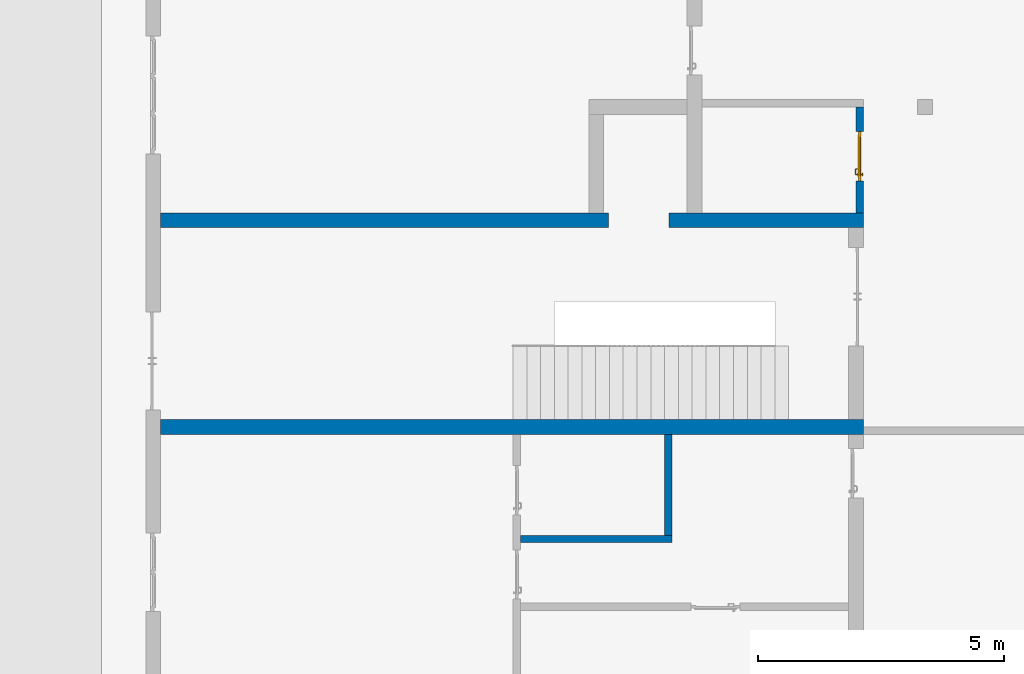
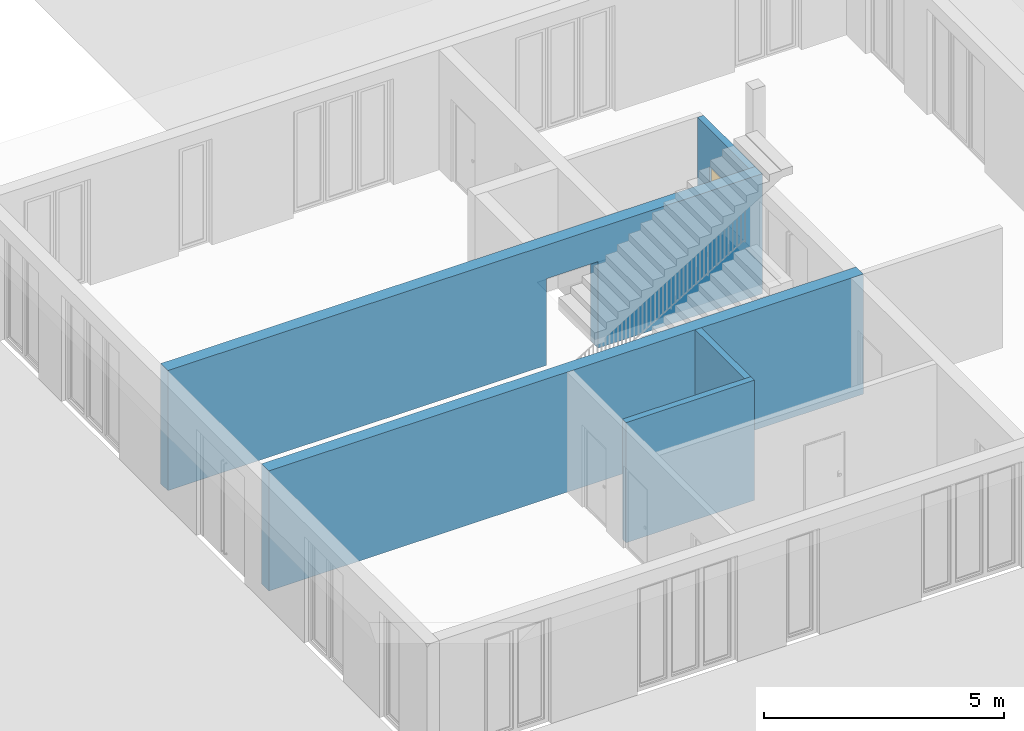
# One storey, part 2 of 23: 5 walls, 1 door, 2 openings.
"""IFC4 building model written with IfcOpenShell, lengths in metres."""

from ifc_helpers import new_model, entity, si_unit, converted_unit, derived_unit, direction, frame, origin_with_axes, place, context, subcontext, project, spatial, polygons, source, transform, mapped, material, type_object, element, fill, save


model = new_model("IFC4")

# Units and contexts
model_context = context("Model", 3, precision=1e-05, world=origin_with_axes(), true_north=direction((0.0, 1.0)))
body_context = subcontext(model_context, "Body", "Model", "MODEL_VIEW")
ifc_project = project(units=[si_unit("LENGTHUNIT", "METRE"), si_unit("AREAUNIT", "SQUARE_METRE"), si_unit("VOLUMEUNIT", "CUBIC_METRE"), converted_unit("PLANEANGLEUNIT", "DEGREE", entity("IfcPlaneAngleMeasure", 0.0174532925199), si_unit("PLANEANGLEUNIT", "RADIAN"), dimensions=[0, 0, 0, 0, 0, 0, 0]), converted_unit("TIMEUNIT", "Year", entity("IfcTimeMeasure", 31556926.0), si_unit("TIMEUNIT", "SECOND"), dimensions=[0, 0, 1, 0, 0, 0, 0]), si_unit("MASSUNIT", "GRAM", prefix="KILO"), si_unit("THERMODYNAMICTEMPERATUREUNIT", "DEGREE_CELSIUS"), si_unit("LUMINOUSINTENSITYUNIT", "LUMEN"), si_unit("ENERGYUNIT", "JOULE", prefix="MEGA"), derived_unit("THERMALCONDUCTANCEUNIT", [(si_unit("POWERUNIT", "WATT"), 1), (si_unit("LENGTHUNIT", "METRE"), -1), (si_unit("THERMODYNAMICTEMPERATUREUNIT", "KELVIN"), -1)]), derived_unit("SPECIFICHEATCAPACITYUNIT", [(si_unit("ENERGYUNIT", "JOULE"), 1), (si_unit("MASSUNIT", "GRAM", prefix="KILO"), -1), (si_unit("THERMODYNAMICTEMPERATUREUNIT", "KELVIN"), -1)]), derived_unit("MASSDENSITYUNIT", [(si_unit("MASSUNIT", "GRAM", prefix="KILO"), 1), (si_unit("VOLUMEUNIT", "CUBIC_METRE"), -1)])], contexts=[model_context])

# Site, building, storey
site_placement = place(None, origin_with_axes())
site = spatial("IfcSite", under=ifc_project, at=site_placement, CompositionType="ELEMENT")
building_placement = place(site_placement, origin_with_axes())
building = spatial("IfcBuilding", under=site, at=building_placement, CompositionType="ELEMENT")
storey_placement = place(building_placement, origin_with_axes())
storey = spatial("IfcBuildingStorey", under=building, at=storey_placement, Name="0. Geschoss", CompositionType="ELEMENT", Elevation=0.0)

# Wall
ifc_material = material()
wall_type_1 = type_object("IfcWallType", Name="300", PredefinedType="NOTDEFINED")
wall_1_placement = place(storey_placement, frame((2.8378006196, -2.52881223104, 0.0), z_axis=(0.0, 0.0, 1.0), x_axis=(-1.0, 0.0, 0.0)))
element("IfcWall", 1, at=wall_1_placement, inside=storey, type_object=wall_type_1, material=ifc_material, Name="Wand-001", PredefinedType="NOTDEFINED", context=body_context, shape_type="Tessellation", body=[
    polygons([(14.28, 0.0, 3.05), (6.28, 0.0, 3.05), (1.8, 0.0, 3.05), (0.0, 0.0, 3.05), (0.0, 0.0, 0.0), (14.28, 0.0, 0.0), (14.28, 0.3, 3.05), (0.0, 0.3, 3.05), (0.0, 0.3, 0.0), (14.28, 0.3, 0.0)], [[[1, 2, 3, 4, 5, 6]], [[4, 3, 2, 1, 7, 8]], [[5, 4, 8, 9]], [[9, 10, 6, 5]], [[10, 7, 1, 6]], [[8, 7, 10, 9]]], closed=True),
])

# Wall, opening
wall_2_placement = place(storey_placement, frame((-11.7421993804, 1.37118776896, 0.0), z_axis=(0.0, 0.0, 1.0), x_axis=(1.0, 0.0, 0.0)))
wall_2 = element("IfcWall", 2, at=wall_2_placement, inside=storey, type_object=wall_type_1, material=ifc_material, Name="Wand-001", PredefinedType="NOTDEFINED", context=body_context, shape_type="Tessellation", body=[
    polygons([(9.4, 0.3, 2.2), (9.4, 0.3, 0.0), (0.3, 0.3, 0.0), (0.3, 0.3, 3.05), (14.58, 0.3, 3.05), (14.58, 0.3, 0.0), (10.63, 0.3, 0.0), (10.63, 0.3, 2.2), (9.4, 0.0, 2.2), (9.4, 0.0, 0.0), (0.3, 0.0, 0.0), (0.3, 0.0, 3.05), (14.58, 0.0, 3.05), (14.58, 0.0, 0.0), (10.63, 0.0, 0.0), (10.63, 0.0, 2.2)], [[[1, 2, 3, 4, 5, 6, 7, 8]], [[2, 1, 9, 10]], [[2, 10, 11, 3]], [[12, 4, 3, 11]], [[13, 5, 4, 12]], [[5, 13, 14, 6]], [[15, 7, 6, 14]], [[8, 7, 15, 16]], [[1, 8, 16, 9]], [[16, 15, 14, 13, 12, 11, 10, 9]]], closed=True),
])
opening_1_placement = place(wall_2_placement, frame((10.015, 0.0, 0.0), z_axis=(0.0, 0.0, 1.0), x_axis=(1.0, 0.0, 0.0)))
element("IfcOpeningElement", 3, at=opening_1_placement, cuts=wall_2, context=body_context, identifier="Reference", shape_type="Tessellation", body=[
    polygons([(-0.615, -0.001, 2.2), (-0.615, -0.001, 0.0), (0.615, -0.001, 0.0), (0.615, -0.001, 2.2), (-0.615, 0.301, 2.2), (-0.615, 0.301, 0.0), (0.615, 0.301, 0.0), (0.615, 0.301, 2.2)], [[[1, 2, 3, 4]], [[5, 6, 2, 1]], [[6, 7, 3, 2]], [[7, 8, 4, 3]], [[8, 5, 1, 4]], [[7, 6, 5, 8]]], closed=True),
])

# Wall
wall_type_2 = type_object("IfcWallType", Name="150", PredefinedType="NOTDEFINED")
wall_3_placement = place(storey_placement, frame((-1.2021993804, -2.52881223104, 0.0), z_axis=(0.0, 0.0, 1.0), x_axis=(0.0, -1.0, 0.0)))
element("IfcWall", 4, at=wall_3_placement, inside=storey, type_object=wall_type_2, material=ifc_material, Name="Wand-002", PredefinedType="NOTDEFINED", context=body_context, shape_type="Tessellation", body=[
    polygons([(0.3, 0.0, 0.0), (0.3, 0.0, 3.05), (0.3, 0.15, 3.05), (0.3, 0.15, 0.0), (2.35, 0.0, 0.0), (2.35, 0.0, 3.05), (2.35, 0.15, 3.05), (2.35, 0.15, 0.0)], [[[1, 2, 3, 4]], [[5, 6, 2, 1]], [[6, 7, 3, 2]], [[4, 3, 7, 8]], [[4, 8, 5, 1]], [[8, 7, 6, 5]]], closed=True),
])

# Wall, opening, door
wall_4_placement = place(storey_placement, frame((2.8378006196, 1.67118776896, 0.0), z_axis=(0.0, 0.0, 1.0), x_axis=(0.0, 1.0, 0.0)))
wall_4 = element("IfcWall", 5, at=wall_4_placement, inside=storey, type_object=wall_type_2, material=ifc_material, Name="Wand-003", PredefinedType="NOTDEFINED", context=body_context, shape_type="Tessellation", body=[
    polygons([(0.65, 0.0, 2.1), (0.65, 0.15, 2.1), (1.65, 0.15, 2.1), (1.65, 0.0, 2.1), (0.65, 0.05, 0.0), (0.65, 0.15, 0.0), (0.65, 0.0, 0.0), (0.0, 0.15, 0.0), (0.0, 0.15, 3.05), (2.15, 0.15, 3.05), (2.15, 0.15, 0.0), (1.65, 0.15, 0.0), (1.65, 0.05, 0.0), (1.65, 0.0, 0.0), (2.15, 0.0, 3.05), (0.0, 0.0, 3.05), (0.0, 0.0, 0.0), (2.15, 0.0, 0.0)], [[[1, 2, 3, 4]], [[5, 6, 2, 1, 7]], [[2, 6, 8, 9, 10, 11, 12, 3]], [[4, 3, 12, 13, 14]], [[15, 16, 17, 7, 1, 4, 14, 18]], [[6, 5, 7, 17, 8]], [[9, 8, 17, 16]], [[15, 10, 9, 16]], [[15, 18, 11, 10]], [[13, 12, 11, 18, 14]]], closed=True),
])
opening_2_placement = place(wall_4_placement, frame((1.15, 0.0, 0.0), z_axis=(0.0, 0.0, 1.0), x_axis=(1.0, 0.0, 0.0)))
opening_2 = element("IfcOpeningElement", 6, at=opening_2_placement, cuts=wall_4, context=body_context, identifier="Reference", shape_type="Tessellation", body=[
    polygons([(0.5, 0.05, 0.0), (0.5, 0.05, 2.1), (0.5, -0.001, 2.1), (0.5, -0.001, 0.0), (0.5, 0.151, 0.0), (0.5, 0.151, 2.1), (-0.5, 0.05, 2.1), (-0.5, -0.001, 2.1), (-0.5, 0.151, 2.1), (-0.5, -0.001, 0.0), (-0.5, 0.05, 0.0), (-0.5, 0.151, 0.0)], [[[1, 2, 3, 4]], [[2, 1, 5, 6]], [[7, 8, 3, 2, 6, 9]], [[8, 10, 4, 3]], [[1, 4, 10, 11, 12, 5]], [[6, 5, 12, 9]], [[7, 11, 10, 8]], [[11, 7, 9, 12]]], closed=True),
])
door_type = type_object("IfcDoorType", Name="Eingang 01 1-Fl 26", OperationType="SINGLE_SWING_RIGHT", PredefinedType="DOOR")
shared_shape = source(origin_with_axes(), body_context, "Body", "Tessellation", [
    polygons([(0.5, -0.05, 0.0), (0.5, -0.03, 0.0), (0.5, -0.03, 2.1), (0.5, -0.05, 2.1), (0.4, -0.05, 0.0), (0.4, -0.03, 0.0), (0.4, -0.03, 2.0), (0.1301, -0.03, 2.0), (0.0001, -0.03, 2.0), (-0.4, -0.03, 2.0), (-0.4, -0.03, 0.0), (-0.5, -0.03, 0.0), (-0.5, -0.03, 2.1), (-0.5, -0.05, 2.1), (-0.5, -0.05, 0.0), (-0.4, -0.05, 0.0), (-0.4, -0.05, 2.0), (0.0001, -0.05, 2.0), (0.1301, -0.05, 2.0), (0.4, -0.05, 2.0)], [[[1, 2, 3, 4]], [[5, 6, 2, 1]], [[2, 6, 7, 8, 9, 10, 11, 12, 13, 3]], [[4, 3, 13, 14]], [[1, 4, 14, 15, 16, 17, 18, 19, 20, 5]], [[20, 7, 6, 5]], [[19, 8, 7, 20]], [[18, 9, 8, 19]], [[17, 10, 9, 18]], [[16, 11, 10, 17]], [[15, 12, 11, 16]], [[14, 13, 12, 15]]], closed=True),
    polygons([(0.5, -0.03, 0.0), (0.5, 0.0, 0.0), (0.5, 0.0, 2.1), (0.5, -0.03, 2.1), (0.43, -0.03, 0.0), (0.43, 0.0, 0.0), (0.43, 0.0, 2.03), (0.1001, 0.0, 2.03), (0.0301, 0.0, 2.03), (-0.43, 0.0, 2.03), (-0.43, 0.0, 0.0), (-0.5, 0.0, 0.0), (-0.5, 0.0, 2.1), (-0.5, -0.03, 2.1), (-0.5, -0.03, 0.0), (-0.43, -0.03, 0.0), (-0.43, -0.03, 2.03), (0.0301, -0.03, 2.03), (0.1001, -0.03, 2.03), (0.43, -0.03, 2.03)], [[[1, 2, 3, 4]], [[5, 6, 2, 1]], [[2, 6, 7, 8, 9, 10, 11, 12, 13, 3]], [[4, 3, 13, 14]], [[1, 4, 14, 15, 16, 17, 18, 19, 20, 5]], [[20, 7, 6, 5]], [[19, 8, 7, 20]], [[18, 9, 8, 19]], [[17, 10, 9, 18]], [[16, 11, 10, 17]], [[15, 12, 11, 16]], [[14, 13, 12, 15]]], closed=True),
    polygons([(0.43, 0.01, 0.0), (-0.43, 0.01, 0.0), (-0.43, 0.01, 2.03), (0.43, 0.01, 2.03), (0.43, -0.03, 0.0), (-0.43, -0.03, 0.0), (-0.43, -0.03, 2.03), (0.43, -0.03, 2.03)], [[[1, 2, 3, 4]], [[2, 1, 5, 6]], [[3, 2, 6, 7]], [[4, 3, 7, 8]], [[1, 4, 8, 5]], [[6, 5, 8, 7]]], closed=True),
    polygons([(0.395, -0.05, 0.0), (0.395, -0.05, 0.05), (-0.395, -0.05, 0.05), (-0.395, -0.05, 0.0), (0.395, -0.03, 0.0), (0.395, -0.03, 0.07), (0.395, -0.035, 0.07), (-0.395, -0.035, 0.07), (-0.395, -0.03, 0.07), (-0.395, -0.03, 0.0)], [[[1, 2, 3, 4]], [[1, 5, 6, 7, 2]], [[2, 7, 8, 3]], [[4, 3, 8, 9, 10]], [[5, 1, 4, 10]], [[6, 5, 10, 9]], [[7, 6, 9, 8]]], closed=True),
    polygons([(-0.3835, 0.02, 1.0733826859), (-0.3835, 0.0199, 1.0733826859), (-0.37, 0.0199, 1.077), (-0.37, 0.02, 1.077), (-0.393382685902, 0.02, 1.0635), (-0.393382685902, 0.0199, 1.0635), (-0.3835, 0.0101, 1.0733826859), (-0.37, 0.0101, 1.077), (-0.3565, 0.0199, 1.0733826859), (-0.3565, 0.02, 1.0733826859), (-0.346617314098, 0.02, 1.0635), (-0.343, 0.02, 1.05), (-0.346617314098, 0.02, 1.0365), (-0.3565, 0.02, 1.0266173141), (-0.37, 0.02, 1.023), (-0.3835, 0.02, 1.0266173141), (-0.393382685902, 0.02, 1.0365), (-0.397, 0.02, 1.05), (-0.397, 0.0199, 1.05), (-0.393382685902, 0.0101, 1.0635), (-0.3835, 0.01, 1.0733826859), (-0.37, 0.01, 1.077), (-0.3565, 0.0101, 1.0733826859), (-0.346617314098, 0.0199, 1.0635), (-0.343, 0.0199, 1.05), (-0.346617314098, 0.0199, 1.0365), (-0.3565, 0.0199, 1.0266173141), (-0.37, 0.0199, 1.023), (-0.3835, 0.0199, 1.0266173141), (-0.393382685902, 0.0199, 1.0365), (-0.397, 0.0101, 1.05), (-0.393382685902, 0.01, 1.0635), (-0.397, 0.01, 1.05), (-0.393382685902, 0.01, 1.0365), (-0.3835, 0.01, 1.0266173141), (-0.37, 0.01, 1.023), (-0.3565, 0.01, 1.0266173141), (-0.346617314098, 0.01, 1.0365), (-0.343, 0.01, 1.05), (-0.346617314098, 0.01, 1.0635), (-0.3565, 0.01, 1.0733826859), (-0.346617314098, 0.0101, 1.0635), (-0.343, 0.0101, 1.05), (-0.346617314098, 0.0101, 1.0365), (-0.3565, 0.0101, 1.0266173141), (-0.37, 0.0101, 1.023), (-0.3835, 0.0101, 1.0266173141), (-0.393382685902, 0.0101, 1.0365)], [[[1, 2, 3, 4]], [[5, 6, 2, 1]], [[2, 7, 8, 3]], [[4, 3, 9, 10]], [[4, 10, 11, 12, 13, 14, 15, 16, 17, 18, 5, 1]], [[18, 19, 6, 5]], [[6, 20, 7, 2]], [[7, 21, 22, 8]], [[3, 8, 23, 9]], [[10, 9, 24, 11]], [[11, 24, 25, 12]], [[12, 25, 26, 13]], [[13, 26, 27, 14]], [[14, 27, 28, 15]], [[15, 28, 29, 16]], [[16, 29, 30, 17]], [[17, 30, 19, 18]], [[19, 31, 20, 6]], [[20, 32, 21, 7]], [[22, 21, 32, 33, 34, 35, 36, 37, 38, 39, 40, 41]], [[8, 22, 41, 23]], [[9, 23, 42, 24]], [[24, 42, 43, 25]], [[25, 43, 44, 26]], [[26, 44, 45, 27]], [[27, 45, 46, 28]], [[28, 46, 47, 29]], [[29, 47, 48, 30]], [[30, 48, 31, 19]], [[31, 33, 32, 20]], [[48, 34, 33, 31]], [[47, 35, 34, 48]], [[46, 36, 35, 47]], [[45, 37, 36, 46]], [[44, 38, 37, 45]], [[43, 39, 38, 44]], [[42, 40, 39, 43]], [[23, 41, 40, 42]]], closed=True),
    polygons([(-0.362532169224, 0.019, 0.959692280177), (-0.365, 0.019, 0.9544), (-0.365, 0.019, 0.952886751346), (-0.347569942042, 0.019, 0.96295), (-0.35705, 0.019, 0.972430057958), (-0.363279754556, 0.019, 0.961639806549), (-0.362532169224, 0.02, 0.959692280177), (-0.365, 0.02, 0.9544), (-0.365, 0.02, 0.952886751346), (-0.365, 0.02, 0.95), (-0.365, 0.02, 0.947113248654), (-0.365, 0.02, 0.941339745962), (-0.365, 0.02, 0.9375), (-0.365, 0.019, 0.9375), (-0.365, 0.019, 0.941339745962), (-0.365, 0.019, 0.947113248654), (-0.365, 0.019, 0.95), (-0.3441, 0.019, 0.95), (-0.347483339502, 0.019, 0.963), (-0.357, 0.019, 0.972516660498), (-0.364624817685, 0.019, 0.965143815798), (-0.37, 0.019, 0.9759), (-0.37, 0.019, 0.967425445323), (-0.364624817685, 0.02, 0.965143815798), (-0.363279754556, 0.02, 0.961639806549), (-0.35655, 0.02, 0.973296083362), (-0.346703916638, 0.02, 0.96345), (-0.3431, 0.02, 0.95), (-0.346703916638, 0.02, 0.93655), (-0.35655, 0.02, 0.926703916638), (-0.37, 0.02, 0.9231), (-0.37, 0.02, 0.9325), (-0.366464466094, 0.02, 0.933964466094), (-0.366464466094, 0.019, 0.933964466094), (-0.35705, 0.019, 0.927569942042), (-0.37, 0.019, 0.9325), (-0.37, 0.019, 0.9241), (-0.347569942042, 0.019, 0.93705), (-0.344, 0.019, 0.95), (-0.347483339502, 0.0189, 0.963), (-0.357, 0.0189, 0.972516660498), (-0.37, 0.019, 0.976), (-0.375375182315, 0.019, 0.965143815798), (-0.38295, 0.019, 0.972430057958), (-0.376720245444, 0.019, 0.961639806549), (-0.37, 0.02, 0.967425445323), (-0.37, 0.02, 0.9769), (-0.346617314098, 0.02, 0.9635), (-0.3565, 0.02, 0.973382685902), (-0.343, 0.02, 0.95), (-0.346617314098, 0.02, 0.9365), (-0.3565, 0.02, 0.926617314098), (-0.38345, 0.02, 0.926703916638), (-0.375, 0.02, 0.941339745962), (-0.375, 0.02, 0.9375), (-0.373535533906, 0.02, 0.933964466094), (-0.37, 0.02, 0.923), (-0.373535533906, 0.019, 0.933964466094), (-0.375, 0.019, 0.9375), (-0.375, 0.019, 0.941339745962), (-0.38295, 0.019, 0.927569942042), (-0.37, 0.019, 0.924), (-0.357, 0.019, 0.927483339502), (-0.347483339502, 0.019, 0.937), (-0.344, 0.0189, 0.95), (-0.347483339502, 0.0101, 0.963), (-0.357, 0.0101, 0.972516660498), (-0.37, 0.0189, 0.976), (-0.383, 0.019, 0.972516660498), (-0.375375182315, 0.02, 0.965143815798), (-0.377467830776, 0.019, 0.959692280177), (-0.392430057958, 0.019, 0.96295), (-0.375, 0.019, 0.952886751346), (-0.375, 0.019, 0.9544), (-0.377467830776, 0.02, 0.959692280177), (-0.376720245444, 0.02, 0.961639806549), (-0.38345, 0.02, 0.973296083362), (-0.37, 0.02, 0.977), (-0.346617314098, 0.0199, 0.9635), (-0.3565, 0.0199, 0.973382685902), (-0.343, 0.0199, 0.95), (-0.346617314098, 0.0199, 0.9365), (-0.3565, 0.0199, 0.926617314098), (-0.393296083362, 0.02, 0.93655), (-0.375, 0.02, 0.947113248654), (-0.375, 0.02, 0.9544), (-0.375, 0.019, 0.95), (-0.375, 0.019, 0.947113248654), (-0.375, 0.02, 0.95), (-0.375, 0.02, 0.952886751346), (-0.3835, 0.02, 0.926617314098), (-0.37, 0.0199, 0.923), (-0.392430057958, 0.019, 0.93705), (-0.383, 0.019, 0.927483339502), (-0.37, 0.0189, 0.924), (-0.357, 0.0189, 0.927483339502), (-0.347483339502, 0.0189, 0.937), (-0.344, 0.0101, 0.95), (-0.347483339502, 0.01, 0.963), (-0.357, 0.01, 0.972516660498), (-0.37, 0.0101, 0.976), (-0.383, 0.0189, 0.972516660498), (-0.392516660498, 0.019, 0.963), (-0.3959, 0.019, 0.95), (-0.393296083362, 0.02, 0.96345), (-0.3835, 0.02, 0.973382685902), (-0.37, 0.0199, 0.977), (-0.346617314098, 0.0101, 0.9635), (-0.3565, 0.0101, 0.973382685902), (-0.343, 0.0101, 0.95), (-0.346617314098, 0.0101, 0.9365), (-0.3565, 0.0101, 0.926617314098), (-0.393382685902, 0.02, 0.9365), (-0.3969, 0.02, 0.95), (-0.3835, 0.0199, 0.926617314098), (-0.37, 0.0101, 0.923), (-0.392516660498, 0.019, 0.937), (-0.383, 0.0189, 0.927483339502), (-0.37, 0.0101, 0.924), (-0.357, 0.0101, 0.927483339502), (-0.347483339502, 0.0101, 0.937), (-0.344, 0.01, 0.95), (-0.347396736961, 0.01, 0.96305), (-0.35695, 0.01, 0.972603263039), (-0.37, 0.01, 0.976), (-0.383, 0.0101, 0.972516660498), (-0.392516660498, 0.0189, 0.963), (-0.396, 0.019, 0.95), (-0.393382685902, 0.02, 0.9635), (-0.3835, 0.0199, 0.973382685902), (-0.37, 0.0101, 0.977), (-0.346617314098, 0.01, 0.9635), (-0.3565, 0.01, 0.973382685902), (-0.343, 0.01, 0.95), (-0.346617314098, 0.01, 0.9365), (-0.3565, 0.01, 0.926617314098), (-0.397, 0.02, 0.95), (-0.393382685902, 0.0199, 0.9365), (-0.3835, 0.0101, 0.926617314098), (-0.37, 0.01, 0.923), (-0.392516660498, 0.0189, 0.937), (-0.383, 0.0101, 0.927483339502), (-0.37, 0.01, 0.924), (-0.357, 0.01, 0.927483339502), (-0.347483339502, 0.01, 0.937), (-0.3439, 0.01, 0.95), (-0.346703916638, 0.01, 0.96345), (-0.35655, 0.01, 0.973296083362), (-0.37, 0.01, 0.9761), (-0.383, 0.01, 0.972516660498), (-0.392516660498, 0.0101, 0.963), (-0.396, 0.0189, 0.95), (-0.393382685902, 0.0199, 0.9635), (-0.3835, 0.0101, 0.973382685902), (-0.37, 0.01, 0.977), (-0.3431, 0.01, 0.95), (-0.346703916638, 0.01, 0.93655), (-0.35655, 0.01, 0.926703916638), (-0.397, 0.0199, 0.95), (-0.393382685902, 0.0101, 0.9365), (-0.3835, 0.01, 0.926617314098), (-0.37, 0.01, 0.9231), (-0.392516660498, 0.0101, 0.937), (-0.383, 0.01, 0.927483339502), (-0.37, 0.01, 0.9239), (-0.35695, 0.01, 0.927396736961), (-0.347396736961, 0.01, 0.93695), (-0.37, 0.01, 0.9769), (-0.38305, 0.01, 0.972603263039), (-0.392516660498, 0.01, 0.963), (-0.396, 0.0101, 0.95), (-0.393382685902, 0.0101, 0.9635), (-0.3835, 0.01, 0.973382685902), (-0.397, 0.0101, 0.95), (-0.393382685902, 0.01, 0.9365), (-0.38345, 0.01, 0.926703916638), (-0.392516660498, 0.01, 0.937), (-0.38305, 0.01, 0.927396736961), (-0.38345, 0.01, 0.973296083362), (-0.392603263039, 0.01, 0.96305), (-0.396, 0.01, 0.95), (-0.393382685902, 0.01, 0.9635), (-0.397, 0.01, 0.95), (-0.393296083362, 0.01, 0.93655), (-0.392603263039, 0.01, 0.93695), (-0.393296083362, 0.01, 0.96345), (-0.3961, 0.01, 0.95), (-0.3969, 0.01, 0.95)], [[[1, 2, 3, 4, 5, 6]], [[2, 1, 7, 8]], [[2, 8, 9, 10, 11, 12, 13, 14, 15, 16, 17, 3]], [[17, 18, 4, 3]], [[4, 19, 20, 5]], [[21, 6, 5, 22, 23]], [[1, 6, 21, 24, 25, 7]], [[7, 25, 26, 27, 9, 8]], [[9, 27, 28, 10]], [[10, 28, 29, 11]], [[11, 29, 30, 12]], [[31, 32, 33, 13, 12, 30]], [[14, 13, 33, 34]], [[35, 15, 14, 34, 36, 37]], [[15, 35, 38, 16]], [[16, 38, 18, 17]], [[18, 39, 19, 4]], [[19, 40, 41, 20]], [[5, 20, 42, 22]], [[43, 23, 22, 44, 45]], [[21, 23, 46, 24]], [[24, 46, 47, 26, 25]], [[48, 27, 26, 49]], [[50, 28, 27, 48]], [[51, 29, 28, 50]], [[52, 30, 29, 51]], [[53, 54, 55, 56, 32, 31]], [[34, 33, 32, 36]], [[57, 31, 30, 52]], [[37, 36, 58, 59, 60, 61]], [[37, 62, 63, 35]], [[35, 63, 64, 38]], [[38, 64, 39, 18]], [[39, 65, 40, 19]], [[40, 66, 67, 41]], [[20, 41, 68, 42]], [[22, 42, 69, 44]], [[23, 43, 70, 46]], [[71, 45, 44, 72, 73, 74]], [[43, 45, 71, 75, 76, 70]], [[70, 76, 77, 47, 46]], [[49, 26, 47, 78]], [[79, 48, 49, 80]], [[81, 50, 48, 79]], [[82, 51, 50, 81]], [[83, 52, 51, 82]], [[54, 53, 84, 85]], [[86, 74, 73, 87, 88, 60, 59, 55, 54, 85, 89, 90]], [[58, 56, 55, 59]], [[36, 32, 56, 58]], [[91, 53, 31, 57]], [[92, 57, 52, 83]], [[88, 93, 61, 60]], [[61, 94, 62, 37]], [[62, 95, 96, 63]], [[63, 96, 97, 64]], [[64, 97, 65, 39]], [[65, 98, 66, 40]], [[66, 99, 100, 67]], [[41, 67, 101, 68]], [[42, 68, 102, 69]], [[44, 69, 103, 72]], [[73, 72, 104, 87]], [[71, 74, 86, 75]], [[75, 86, 90, 105, 77, 76]], [[78, 47, 77, 106]], [[80, 49, 78, 107]], [[108, 79, 80, 109]], [[110, 81, 79, 108]], [[111, 82, 81, 110]], [[112, 83, 82, 111]], [[113, 84, 53, 91]], [[85, 84, 114, 89]], [[87, 104, 93, 88]], [[89, 114, 105, 90]], [[115, 91, 57, 92]], [[116, 92, 83, 112]], [[93, 117, 94, 61]], [[94, 118, 95, 62]], [[95, 119, 120, 96]], [[96, 120, 121, 97]], [[97, 121, 98, 65]], [[98, 122, 99, 66]], [[99, 123, 124, 100]], [[67, 100, 125, 101]], [[68, 101, 126, 102]], [[69, 102, 127, 103]], [[72, 103, 128, 104]], [[106, 77, 105, 129]], [[107, 78, 106, 130]], [[109, 80, 107, 131]], [[132, 108, 109, 133]], [[134, 110, 108, 132]], [[135, 111, 110, 134]], [[136, 112, 111, 135]], [[137, 114, 84, 113]], [[138, 113, 91, 115]], [[104, 128, 117, 93]], [[129, 105, 114, 137]], [[139, 115, 92, 116]], [[140, 116, 112, 136]], [[117, 141, 118, 94]], [[118, 142, 119, 95]], [[119, 143, 144, 120]], [[120, 144, 145, 121]], [[121, 145, 122, 98]], [[122, 146, 123, 99]], [[123, 147, 148, 124]], [[100, 124, 149, 125]], [[101, 125, 150, 126]], [[102, 126, 151, 127]], [[103, 127, 152, 128]], [[130, 106, 129, 153]], [[131, 107, 130, 154]], [[133, 109, 131, 155]], [[147, 132, 133, 148]], [[156, 134, 132, 147]], [[157, 135, 134, 156]], [[158, 136, 135, 157]], [[159, 137, 113, 138]], [[160, 138, 115, 139]], [[128, 152, 141, 117]], [[153, 129, 137, 159]], [[161, 139, 116, 140]], [[162, 140, 136, 158]], [[141, 163, 142, 118]], [[142, 164, 143, 119]], [[143, 165, 166, 144]], [[144, 166, 167, 145]], [[145, 167, 146, 122]], [[146, 156, 147, 123]], [[124, 148, 168, 149]], [[125, 149, 169, 150]], [[126, 150, 170, 151]], [[127, 151, 171, 152]], [[154, 130, 153, 172]], [[155, 131, 154, 173]], [[148, 133, 155, 168]], [[167, 157, 156, 146]], [[166, 158, 157, 167]], [[174, 159, 138, 160]], [[175, 160, 139, 161]], [[152, 171, 163, 141]], [[172, 153, 159, 174]], [[176, 161, 140, 162]], [[165, 162, 158, 166]], [[163, 177, 164, 142]], [[164, 178, 165, 143]], [[149, 168, 179, 169]], [[150, 169, 180, 170]], [[151, 170, 181, 171]], [[173, 154, 172, 182]], [[168, 155, 173, 179]], [[183, 174, 160, 175]], [[184, 175, 161, 176]], [[171, 181, 177, 163]], [[182, 172, 174, 183]], [[178, 176, 162, 165]], [[177, 185, 178, 164]], [[169, 179, 186, 180]], [[170, 180, 187, 181]], [[179, 173, 182, 186]], [[188, 183, 175, 184]], [[185, 184, 176, 178]], [[181, 187, 185, 177]], [[186, 182, 183, 188]], [[180, 186, 188, 187]], [[187, 188, 184, 185]]], closed=True),
    polygons([(-0.38, 0.02, 1.05), (-0.38, 0.0509849140336, 1.05), (-0.377071067812, 0.050696439392, 1.04292893219), (-0.377071067812, 0.02, 1.04292893219), (-0.377071067812, 0.02, 1.05707106781), (-0.377071067812, 0.050696439392, 1.05707106781), (-0.378277987014, 0.0596420579258, 1.05), (-0.375518993221, 0.0584992452783, 1.04292893219), (-0.37, 0.05, 1.04), (-0.37, 0.02, 1.04), (-0.37, 0.02, 1.06), (-0.37, 0.05, 1.06), (-0.375518993221, 0.0584992452783, 1.05707106781), (-0.372816199938, 0.0678161999379, 1.05), (-0.370704557509, 0.0657045575088, 1.04292893219), (-0.368858192988, 0.0557402514855, 1.04), (-0.362928932188, 0.049303560608, 1.04292893219), (-0.362928932188, 0.02, 1.04292893219), (-0.362928932188, 0.02, 1.05707106781), (-0.362928932188, 0.049303560608, 1.05707106781), (-0.368858192988, 0.0557402514855, 1.06), (-0.370704557509, 0.0657045575088, 1.05707106781), (-0.364642057926, 0.0732779870137, 1.05), (-0.363499245278, 0.0705189932208, 1.04292893219), (-0.365606601718, 0.0606066017178, 1.04), (-0.362197392755, 0.0529812576926, 1.04292893219), (-0.36, 0.0490150859664, 1.05), (-0.36, 0.02, 1.05), (-0.362197392755, 0.0529812576926, 1.05707106781), (-0.365606601718, 0.0606066017178, 1.06), (-0.363499245278, 0.0705189932208, 1.05707106781), (-0.355984914034, 0.075, 1.05), (-0.355696439392, 0.0720710678119, 1.04292893219), (-0.360740251485, 0.0638581929877, 1.04), (-0.360508645927, 0.0555086459268, 1.04292893219), (-0.359438398962, 0.0518384450452, 1.05), (-0.360508645927, 0.0555086459268, 1.05707106781), (-0.360740251485, 0.0638581929877, 1.06), (-0.355696439392, 0.0720710678119, 1.05707106781), (-0.274015085966, 0.075, 1.05), (-0.274303560608, 0.0720710678119, 1.04292893219), (-0.355, 0.065, 1.04), (-0.357981257693, 0.0571973927545, 1.04292893219), (-0.358397003498, 0.0533970034977, 1.05), (-0.357981257693, 0.0571973927545, 1.05707106781), (-0.355, 0.065, 1.06), (-0.274303560608, 0.0720710678119, 1.05707106781), (-0.265357942074, 0.0732779870137, 1.05), (-0.266500754722, 0.0705189932208, 1.04292893219), (-0.275, 0.065, 1.04), (-0.354303560608, 0.0579289321881, 1.04292893219), (-0.356838445045, 0.0544383989617, 1.05), (-0.354303560608, 0.0579289321881, 1.05707106781), (-0.275, 0.065, 1.06), (-0.266500754722, 0.0705189932208, 1.05707106781), (-0.257183800062, 0.0678161999379, 1.05), (-0.259295442491, 0.0657045575088, 1.04292893219), (-0.269259748515, 0.0638581929877, 1.04), (-0.275696439392, 0.0579289321881, 1.04292893219), (-0.354015085966, 0.055, 1.05), (-0.275696439392, 0.0579289321881, 1.05707106781), (-0.269259748515, 0.0638581929877, 1.06), (-0.259295442491, 0.0657045575088, 1.05707106781), (-0.251722012986, 0.0596420579258, 1.05), (-0.254481006779, 0.0584992452783, 1.04292893219), (-0.264393398282, 0.0606066017178, 1.04), (-0.272018742307, 0.0571973927545, 1.04292893219), (-0.275984914034, 0.055, 1.05), (-0.272018742307, 0.0571973927545, 1.05707106781), (-0.264393398282, 0.0606066017178, 1.06), (-0.254481006779, 0.0584992452783, 1.05707106781), (-0.25, 0.0509849140336, 1.05), (-0.252928932188, 0.050696439392, 1.04292893219), (-0.261141807012, 0.0557402514855, 1.04), (-0.269491354073, 0.0555086459268, 1.04292893219), (-0.273161554955, 0.0544383989617, 1.05), (-0.269491354073, 0.0555086459268, 1.05707106781), (-0.261141807012, 0.0557402514855, 1.06), (-0.252928932188, 0.050696439392, 1.05707106781), (-0.25, 0.02, 1.05), (-0.252928932188, 0.02, 1.04292893219), (-0.26, 0.05, 1.04), (-0.267802607245, 0.0529812576926, 1.04292893219), (-0.271602996502, 0.0533970034977, 1.05), (-0.267802607245, 0.0529812576926, 1.05707106781), (-0.26, 0.05, 1.06), (-0.252928932188, 0.02, 1.05707106781), (-0.26, 0.02, 1.06), (-0.267071067812, 0.02, 1.05707106781), (-0.27, 0.02, 1.05), (-0.267071067812, 0.02, 1.04292893219), (-0.26, 0.02, 1.04), (-0.267071067812, 0.049303560608, 1.04292893219), (-0.270561601038, 0.0518384450452, 1.05), (-0.267071067812, 0.049303560608, 1.05707106781), (-0.27, 0.0490150859664, 1.05)], [[[1, 2, 3, 4]], [[5, 6, 2, 1]], [[2, 7, 8, 3]], [[4, 3, 9, 10]], [[11, 12, 6, 5]], [[6, 13, 7, 2]], [[7, 14, 15, 8]], [[3, 8, 16, 9]], [[10, 9, 17, 18]], [[19, 20, 12, 11]], [[12, 21, 13, 6]], [[13, 22, 14, 7]], [[14, 23, 24, 15]], [[8, 15, 25, 16]], [[9, 16, 26, 17]], [[18, 17, 27, 28]], [[28, 27, 20, 19]], [[20, 29, 21, 12]], [[21, 30, 22, 13]], [[22, 31, 23, 14]], [[23, 32, 33, 24]], [[15, 24, 34, 25]], [[16, 25, 35, 26]], [[17, 26, 36, 27]], [[27, 36, 29, 20]], [[29, 37, 30, 21]], [[30, 38, 31, 22]], [[31, 39, 32, 23]], [[32, 40, 41, 33]], [[24, 33, 42, 34]], [[25, 34, 43, 35]], [[26, 35, 44, 36]], [[36, 44, 37, 29]], [[37, 45, 38, 30]], [[38, 46, 39, 31]], [[39, 47, 40, 32]], [[40, 48, 49, 41]], [[33, 41, 50, 42]], [[34, 42, 51, 43]], [[35, 43, 52, 44]], [[44, 52, 45, 37]], [[45, 53, 46, 38]], [[46, 54, 47, 39]], [[47, 55, 48, 40]], [[48, 56, 57, 49]], [[41, 49, 58, 50]], [[42, 50, 59, 51]], [[43, 51, 60, 52]], [[52, 60, 53, 45]], [[53, 61, 54, 46]], [[54, 62, 55, 47]], [[55, 63, 56, 48]], [[56, 64, 65, 57]], [[49, 57, 66, 58]], [[50, 58, 67, 59]], [[51, 59, 68, 60]], [[60, 68, 61, 53]], [[61, 69, 62, 54]], [[62, 70, 63, 55]], [[63, 71, 64, 56]], [[64, 72, 73, 65]], [[57, 65, 74, 66]], [[58, 66, 75, 67]], [[59, 67, 76, 68]], [[68, 76, 69, 61]], [[69, 77, 70, 62]], [[70, 78, 71, 63]], [[71, 79, 72, 64]], [[72, 80, 81, 73]], [[65, 73, 82, 74]], [[66, 74, 83, 75]], [[67, 75, 84, 76]], [[76, 84, 77, 69]], [[77, 85, 78, 70]], [[78, 86, 79, 71]], [[79, 87, 80, 72]], [[80, 87, 88, 89, 90, 91, 92, 81]], [[73, 81, 92, 82]], [[74, 82, 93, 83]], [[75, 83, 94, 84]], [[84, 94, 85, 77]], [[85, 95, 86, 78]], [[86, 88, 87, 79]], [[95, 89, 88, 86]], [[96, 90, 89, 95]], [[93, 91, 90, 96]], [[82, 92, 91, 93]], [[83, 93, 96, 94]], [[94, 96, 95, 85]]], closed=False),
    polygons([(-0.364696699141, -0.035, 1.04469669914), (-0.37, -0.035, 1.0425), (-0.375303300859, -0.035, 1.04469669914), (-0.3775, -0.035, 1.05), (-0.375303300859, -0.035, 1.05530330086), (-0.37, -0.035, 1.0575), (-0.364696699141, -0.035, 1.05530330086), (-0.3625, -0.035, 1.05), (-0.364696699141, -0.075, 1.04469669914), (-0.37, -0.075, 1.0425), (-0.375303300859, -0.075, 1.04469669914), (-0.3775, -0.075, 1.05), (-0.375303300859, -0.075, 1.05530330086), (-0.37, -0.075, 1.0575), (-0.364696699141, -0.075, 1.05530330086), (-0.3625, -0.075, 1.05)], [[[1, 2, 3, 4, 5, 6, 7, 8]], [[2, 1, 9, 10]], [[3, 2, 10, 11]], [[4, 3, 11, 12]], [[5, 4, 12, 13]], [[6, 5, 13, 14]], [[7, 6, 14, 15]], [[8, 7, 15, 16]], [[1, 8, 16, 9]], [[9, 16, 15, 14, 13, 12, 11, 10]]], closed=True),
    polygons([(-0.395, -0.03, 0.975), (-0.393096988313, -0.03, 0.965432914191), (-0.393096988313, -0.035, 0.965432914191), (-0.395, -0.035, 0.975), (-0.395, -0.03, 1.1), (-0.393096988313, -0.03, 1.10956708581), (-0.38767766953, -0.03, 1.11767766953), (-0.379567085809, -0.03, 1.12309698831), (-0.37, -0.03, 1.125), (-0.360432914191, -0.03, 1.12309698831), (-0.35232233047, -0.03, 1.11767766953), (-0.346903011687, -0.03, 1.10956708581), (-0.345, -0.03, 1.1), (-0.345, -0.03, 0.975), (-0.346903011687, -0.03, 0.965432914191), (-0.35232233047, -0.03, 0.95732233047), (-0.360432914191, -0.03, 0.951903011687), (-0.37, -0.03, 0.95), (-0.379567085809, -0.03, 0.951903011687), (-0.38767766953, -0.03, 0.95732233047), (-0.38767766953, -0.035, 0.95732233047), (-0.379567085809, -0.035, 0.951903011687), (-0.37, -0.035, 0.95), (-0.360432914191, -0.035, 0.951903011687), (-0.35232233047, -0.035, 0.95732233047), (-0.346903011687, -0.035, 0.965432914191), (-0.345, -0.035, 0.975), (-0.345, -0.035, 1.1), (-0.346903011687, -0.035, 1.10956708581), (-0.35232233047, -0.035, 1.11767766953), (-0.360432914191, -0.035, 1.12309698831), (-0.37, -0.035, 1.125), (-0.379567085809, -0.035, 1.12309698831), (-0.38767766953, -0.035, 1.11767766953), (-0.393096988313, -0.035, 1.10956708581), (-0.395, -0.035, 1.1)], [[[1, 2, 3, 4]], [[1, 5, 6, 7, 8, 9, 10, 11, 12, 13, 14, 15, 16, 17, 18, 19, 20, 2]], [[2, 20, 21, 3]], [[4, 3, 21, 22, 23, 24, 25, 26, 27, 28, 29, 30, 31, 32, 33, 34, 35, 36]], [[5, 1, 4, 36]], [[6, 5, 36, 35]], [[7, 6, 35, 34]], [[8, 7, 34, 33]], [[9, 8, 33, 32]], [[10, 9, 32, 31]], [[11, 10, 31, 30]], [[12, 11, 30, 29]], [[13, 12, 29, 28]], [[14, 13, 28, 27]], [[15, 14, 27, 26]], [[16, 15, 26, 25]], [[17, 16, 25, 24]], [[18, 17, 24, 23]], [[19, 18, 23, 22]], [[20, 19, 22, 21]]], closed=True),
    polygons([(-0.39, -0.075, 1.08), (-0.395, -0.075, 1.07866025404), (-0.395, -0.09, 1.07866025404), (-0.39, -0.09, 1.08), (-0.35, -0.075, 1.08), (-0.345, -0.075, 1.07866025404), (-0.341339745962, -0.075, 1.075), (-0.34, -0.075, 1.07), (-0.34, -0.075, 1.03), (-0.341339745962, -0.075, 1.025), (-0.345, -0.075, 1.02133974596), (-0.35, -0.075, 1.02), (-0.39, -0.075, 1.02), (-0.395, -0.075, 1.02133974596), (-0.398660254038, -0.075, 1.025), (-0.4, -0.075, 1.03), (-0.4, -0.075, 1.07), (-0.398660254038, -0.075, 1.075), (-0.398660254038, -0.09, 1.075), (-0.4, -0.09, 1.07), (-0.4, -0.09, 1.03), (-0.398660254038, -0.09, 1.025), (-0.395, -0.09, 1.02133974596), (-0.39, -0.09, 1.02), (-0.35, -0.09, 1.02), (-0.345, -0.09, 1.02133974596), (-0.341339745962, -0.09, 1.025), (-0.34, -0.09, 1.03), (-0.34, -0.09, 1.07), (-0.341339745962, -0.09, 1.075), (-0.345, -0.09, 1.07866025404), (-0.35, -0.09, 1.08)], [[[1, 2, 3, 4]], [[1, 5, 6, 7, 8, 9, 10, 11, 12, 13, 14, 15, 16, 17, 18, 2]], [[2, 18, 19, 3]], [[4, 3, 19, 20, 21, 22, 23, 24, 25, 26, 27, 28, 29, 30, 31, 32]], [[5, 1, 4, 32]], [[6, 5, 32, 31]], [[7, 6, 31, 30]], [[8, 7, 30, 29]], [[9, 8, 29, 28]], [[10, 9, 28, 27]], [[11, 10, 27, 26]], [[12, 11, 26, 25]], [[13, 12, 25, 24]], [[14, 13, 24, 23]], [[15, 14, 23, 22]], [[16, 15, 22, 21]], [[17, 16, 21, 20]], [[18, 17, 20, 19]]], closed=True),
])
door_placement = place(opening_2_placement, frame((-0.4, 0.0, 0.0), z_axis=(0.0, 0.0, 1.0), x_axis=(1.0, 0.0, 0.0)))
door = element("IfcDoor", 7, at=door_placement, inside=storey, type_object=door_type, OverallHeight=2.1, OverallWidth=1.0, PredefinedType="DOOR", context=body_context, shape_type="MappedRepresentation", body=[
    mapped(shared_shape, transform((0.4, 0.1, 0.0))),
])
fill(opening_2, door)

# Wall
wall_5_placement = place(storey_placement, frame((-4.2821993804, -5.02881223104, 0.0), z_axis=(0.0, 0.0, 1.0), x_axis=(1.0, 0.0, 0.0)))
element("IfcWall", 8, at=wall_5_placement, inside=storey, type_object=wall_type_2, material=ifc_material, Name="Wand-002", PredefinedType="NOTDEFINED", context=body_context, shape_type="Tessellation", body=[
    polygons([(0.15, 0.15, 0.0), (0.15, 0.15, 3.05), (3.23, 0.15, 3.05), (3.23, 0.15, 0.0), (0.15, 0.0, 0.0), (0.15, 0.0, 3.05), (3.23, 0.0, 3.05), (3.23, 0.0, 0.0)], [[[1, 2, 3, 4]], [[5, 6, 2, 1]], [[6, 7, 3, 2]], [[4, 3, 7, 8]], [[5, 1, 4, 8]], [[8, 7, 6, 5]]], closed=True),
])

save(model, "model.ifc")
